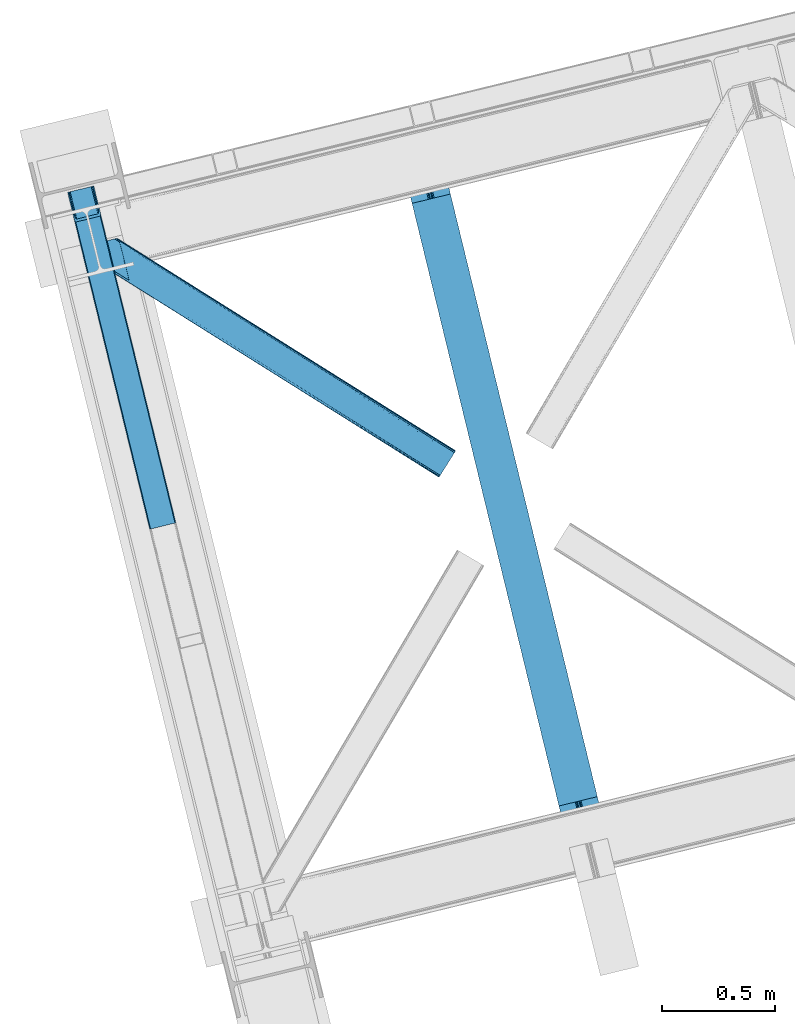
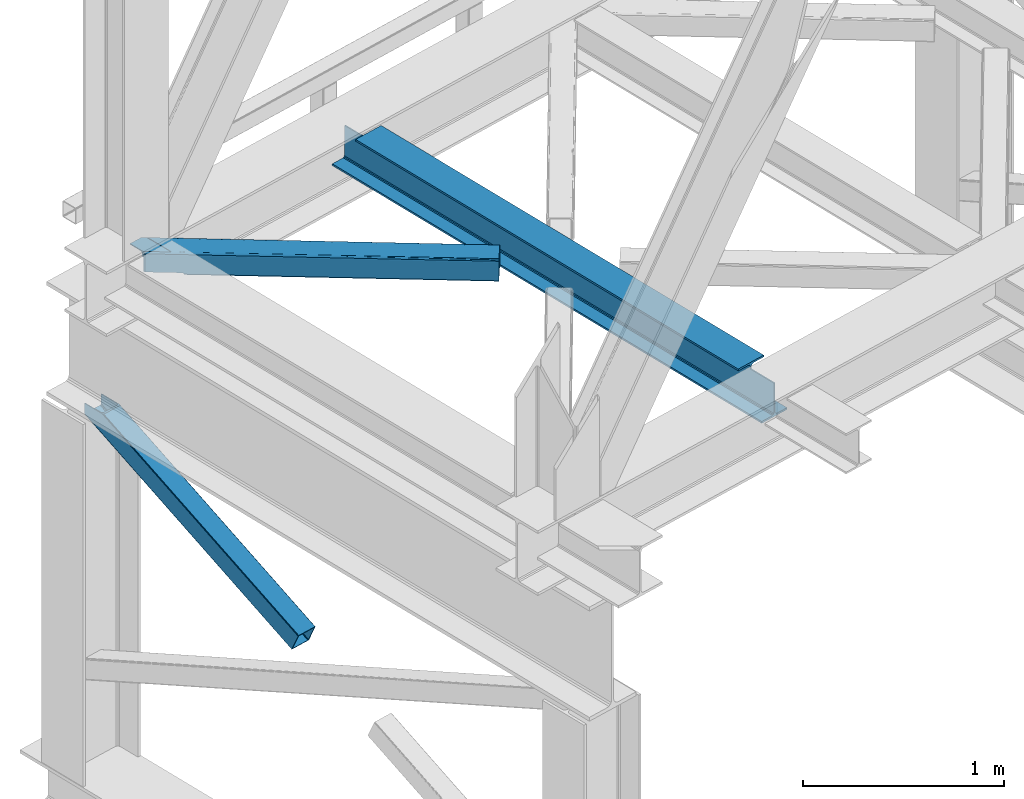
# One storey, part 24 of 93: 2 members, 1 beam.
"""IFC4 building model written with IfcOpenShell, lengths in millimetres."""

from ifc_helpers import new_model, entity, si_unit, converted_unit, derived_unit, direction, frame, origin, place, context, subcontext, project, spatial, triangles, polygons, material, type_object, element, save


model = new_model("IFC4")

# Units and contexts
model_context = context("Model", 3, precision=0.01, world=origin(), true_north=direction((6.12303176911189e-17, 1.0)))
plan_context = context("Plan", 3, precision=0.01, world=origin(), true_north=direction((6.12303176911189e-17, 1.0)))
body_context = subcontext(model_context, "Body", "Model", "MODEL_VIEW")
ifc_project = project(units=[si_unit("LENGTHUNIT", "METRE", prefix="MILLI"), si_unit("AREAUNIT", "SQUARE_METRE"), si_unit("VOLUMEUNIT", "CUBIC_METRE"), converted_unit("PLANEANGLEUNIT", "DEGREE", entity("IfcRatioMeasure", 0.0174532925199433), si_unit("PLANEANGLEUNIT", "RADIAN"), dimensions=[0, 0, 0, 0, 0, 0, 0]), si_unit("MASSUNIT", "GRAM", prefix="KILO"), derived_unit("MASSDENSITYUNIT", [(si_unit("MASSUNIT", "GRAM", prefix="KILO"), 1), (si_unit("LENGTHUNIT", "METRE"), -3)]), derived_unit("MOMENTOFINERTIAUNIT", [(si_unit("LENGTHUNIT", "METRE"), 4)]), si_unit("TIMEUNIT", "SECOND"), si_unit("FREQUENCYUNIT", "HERTZ"), si_unit("THERMODYNAMICTEMPERATUREUNIT", "DEGREE_CELSIUS"), derived_unit("THERMALTRANSMITTANCEUNIT", [(si_unit("MASSUNIT", "GRAM", prefix="KILO"), 1), (si_unit("THERMODYNAMICTEMPERATUREUNIT", "KELVIN"), -1), (si_unit("TIMEUNIT", "SECOND"), -3)]), derived_unit("VOLUMETRICFLOWRATEUNIT", [(si_unit("LENGTHUNIT", "METRE"), 3), (si_unit("TIMEUNIT", "SECOND"), -1)]), derived_unit("MASSFLOWRATEUNIT", [(si_unit("MASSUNIT", "GRAM", prefix="KILO"), 1), (si_unit("TIMEUNIT", "SECOND"), -1)]), derived_unit("ROTATIONALFREQUENCYUNIT", [(si_unit("TIMEUNIT", "SECOND"), -1)]), si_unit("ELECTRICCURRENTUNIT", "AMPERE"), si_unit("ELECTRICVOLTAGEUNIT", "VOLT"), si_unit("POWERUNIT", "WATT"), si_unit("FORCEUNIT", "NEWTON", prefix="KILO"), si_unit("ILLUMINANCEUNIT", "LUX"), si_unit("LUMINOUSFLUXUNIT", "LUMEN"), si_unit("LUMINOUSINTENSITYUNIT", "CANDELA"), derived_unit("USERDEFINED", [(si_unit("MASSUNIT", "GRAM", prefix="KILO"), -1), (si_unit("LENGTHUNIT", "METRE"), -2), (si_unit("TIMEUNIT", "SECOND"), 3), (si_unit("LUMINOUSFLUXUNIT", "LUMEN"), 1)]), derived_unit("LINEARVELOCITYUNIT", [(si_unit("LENGTHUNIT", "METRE"), 1), (si_unit("TIMEUNIT", "SECOND"), -1)]), si_unit("PRESSUREUNIT", "PASCAL"), derived_unit("USERDEFINED", [(si_unit("LENGTHUNIT", "METRE"), -2), (si_unit("MASSUNIT", "GRAM", prefix="KILO"), 1), (si_unit("TIMEUNIT", "SECOND"), -2)]), derived_unit("LINEARFORCEUNIT", [(si_unit("MASSUNIT", "GRAM", prefix="KILO"), 1), (si_unit("LENGTHUNIT", "METRE"), 1), (si_unit("TIMEUNIT", "SECOND"), -2), (si_unit("LENGTHUNIT", "METRE"), -1)]), derived_unit("PLANARFORCEUNIT", [(si_unit("MASSUNIT", "GRAM", prefix="KILO"), 1), (si_unit("LENGTHUNIT", "METRE"), 1), (si_unit("TIMEUNIT", "SECOND"), -2), (si_unit("LENGTHUNIT", "METRE"), -2)])], contexts=[model_context, plan_context])

# Site, building, storey
site_placement = place(None, origin())
site = spatial("IfcSite", under=ifc_project, at=site_placement, CompositionType="ELEMENT")
building_placement = place(site_placement, origin())
building = spatial("IfcBuilding", under=site, at=building_placement, CompositionType="ELEMENT")
storey_placement = place(building_placement, frame((0.0, 0.0, 15900.0)))
storey = spatial("IfcBuildingStorey", under=building, at=storey_placement, CompositionType="ELEMENT", Elevation=15900.0)

# Beam
ifc_material = material(Name="Metal painted (White)")
beam_type = type_object("IfcBeamType", PredefinedType="BEAM")
beam_placement = place(storey_placement, frame((-59635.8888397956, 3249.82596394136, 3441.0)))
element("IfcBeam", 1, at=beam_placement, inside=storey, type_object=beam_type, material=ifc_material, ObjectType="Steel Beam", PredefinedType="BEAM", context=body_context, shape_type="Tessellation", body=[
    polygons([(900.98534618944, 41.4445662733097, 11.000000000004), (900.98534618944, 41.4445662733097, 2.16573425859679e-12), (170.021610174761, 3040.13999372697, 2.16573425859679e-12), (170.021610174761, 3040.13999372697, 11.000000000004), (834.919806235823, 25.3403919499672, 11.000000000004), (103.956070221144, 3024.03581940363, 11.000000000004), (828.971056214531, 23.8903211957396, 12.2179274798217), (98.0073201998513, 3022.5857486494, 12.2179274798217), (823.927949458422, 22.66101056892, 15.6862915010192), (92.9642134437427, 3021.35643802258, 15.6862915010192), (820.558253255246, 21.8396114687124, 20.8770650821657), (89.5945172405668, 3020.53503892237, 20.8770650821657), (819.37497330556, 21.5511744621211, 27.0000000000047), (88.4112372908809, 3020.24660191578, 27.0000000000047), (81.6103728838801, 3018.58881926485, 27.0000000000047), (81.6103728838888, 3018.58881926485, 203.000000000006), (88.4112372908809, 3020.24660191578, 203.000000000006), (0.0, 2998.69542745366, 2.16573425859679e-12), (0.0, 2998.69542745366, 10.9999999999997), (66.0655399536345, 3014.799601777, 11.000000000004), (72.014289974927, 3016.24967253123, 12.2179274798217), (77.057396731027, 3017.47898315805, 15.6862915010192), (80.4270929341942, 3018.30038225826, 20.8770650821657), (819.374973305543, 21.5511744621206, 203.000000000006), (812.574108898559, 19.8933918111892, 203.000000000006), (812.574108898559, 19.8933918111892, 27.0000000000047), (811.390828948873, 19.6049548045968, 20.8770650821657), (808.021132745698, 18.7835557043893, 15.6862915010192), (802.978025989589, 17.5542450775691, 12.2179274798217), (797.029275968296, 16.1041743233431, 11.000000000004), (730.963736014679, 0.0, 10.9999999999997), (730.963736014679, 0.0, 2.16573425859679e-12), (779.675212882757, 184.415062601692, 203.069791966819), (128.020401343512, 2857.75452019162, 203.000000000006), (128.24328213265, 2856.8401777572, 203.617301946336), (128.256196377177, 2856.7871977843, 217.000003693143), (779.530009633824, 185.010597404072, 217.000003676718), (779.530880241731, 185.007025963192, 204.00000679514), (772.964911718311, 182.385463974443, 203.006342981529), (772.742064056782, 183.299815969774, 203.617301946336), (772.729149812263, 183.352795942669, 217.000003693143), (121.455336555608, 2855.1293963229, 217.000003676718), (121.45446594771, 2855.13296776378, 204.00000679514), (121.310166358664, 2855.72494066435, 203.076120467494), (121.219536936511, 2856.09673754069, 203.000000000006), (780.713494357868, 185.298194377515, 223.122939328039), (784.082490766547, 186.122464201394, 228.313710402595), (789.125126170554, 187.353708426698, 231.782072735464), (795.073705041275, 188.80448128138, 232.999999602236), (861.13915590679, 204.909021065315, 232.999999283132), (861.137682570352, 204.915065042188, 243.999994005812), (691.116301666431, 163.469558245298, 243.999994827032), (691.117775002877, 163.463514268425, 233.000000104353), (757.183225868401, 179.568054052359, 232.999999785253), (763.132130996731, 181.017488520583, 231.782072861012), (768.175695503862, 182.244921343719, 228.313710479427), (771.546082413602, 183.063487001148, 223.12293937232), (120.271851831572, 2854.84179934945, 223.122939328039), (116.902855422893, 2854.01752952557, 228.313710402595), (111.860220018869, 2852.78628530027, 231.782072735464), (105.911641148165, 2851.33551244559, 232.999999602236), (39.8461902826505, 2835.23097266165, 232.999999283128), (39.8476636190794, 2835.22492868478, 243.999994005812), (209.869044523001, 2876.67043548167, 243.999994827032), (209.867571186572, 2876.67647945854, 233.000000104357), (143.80212032104, 2860.57193967461, 232.999999785253), (137.85321519271, 2859.12250520639, 231.782072861012), (132.809650685579, 2857.89507238325, 228.313710479427), (129.439263775838, 2857.07650672582, 223.12293937232)], [[[1, 2, 3, 4]], [[5, 1, 4, 6]], [[7, 5, 6, 8]], [[9, 7, 8, 10]], [[11, 9, 10, 12]], [[13, 11, 12, 14]], [[15, 16, 17, 14, 12, 10, 8, 6, 4, 3, 18, 19, 20, 21, 22, 23]], [[13, 24, 25, 26, 27, 28, 29, 30, 31, 32, 2, 1, 5, 7, 9, 11]], [[2, 32, 18, 3]], [[32, 31, 19, 18]], [[31, 30, 20, 19]], [[27, 26, 15, 23]], [[28, 27, 23, 22]], [[29, 28, 22, 21]], [[30, 29, 21, 20]], [[33, 24, 13, 14, 17, 34, 35, 36, 37, 38]], [[25, 39, 40, 41, 42, 43, 44, 16, 15, 26]], [[39, 25, 24, 33]], [[45, 34, 17, 16]], [[41, 40, 38, 37, 46, 47, 48, 49, 50, 51, 52, 53, 54, 55, 56, 57]], [[42, 58, 59, 60, 61, 62, 63, 64, 65, 66, 67, 68, 69, 36, 35, 43]], [[46, 37, 36, 69]], [[47, 46, 69, 68]], [[48, 47, 68, 67]], [[49, 48, 67, 66]], [[50, 49, 66, 65]], [[51, 50, 65, 64]], [[52, 51, 64, 63]], [[53, 52, 63, 62]], [[54, 53, 62, 61]], [[55, 54, 61, 60]], [[56, 55, 60, 59]], [[57, 56, 59, 58]], [[41, 57, 58, 42]]], closed=False),
])

# Members
member_type_1 = type_object("IfcMemberType", PredefinedType="BRACE")
member_1_placement = place(storey_placement, frame((-61123.5760620117, 4641.45331878662, 1850.35374755859)))
element("IfcMember", 2, at=member_1_placement, inside=storey, type_object=member_type_1, ObjectType="Steel Vertical Brace", PredefinedType="BRACE", context=body_context, shape_type="Tessellation", body=[
    triangles([(109.78864746094, 1519.24680175781, 671.707836914062), (462.204345703125, 73.4905723571783, 0.0), (6.80423583984521, 1494.14368286133, 671.707836914062), (359.21993408203, 48.3871627807621, 0.0), (464.859997558597, 73.9117675781254, 0.48601684570167), (467.213342285155, 73.8434577941898, 1.86965332031104), (112.19315185547, 1519.83339385986, 672.832186889649), (468.910913085936, 73.2946540832527, 3.93929443359229), (114.59765625, 1520.41940460205, 673.956536865233), (469.687609863278, 72.3502349853516, 6.38100585937354), (115.592944335935, 1520.66183166504, 676.672650146484), (116.588232421876, 1520.90484008789, 679.387600708007), (353.104028320311, 43.9313301086431, 6.38100585937354), (0.0, 1492.48564453125, 679.387600708007), (0.99993896484375, 1492.7286529541, 676.672650146484), (353.359826660155, 45.128059387207, 3.93929443359229), (1.99522705077834, 1492.97108001709, 673.956536865233), (354.61091308594, 46.3954238891602, 1.86965332031104), (4.39973144531541, 1493.55709075928, 672.832186889649), (356.671252441403, 47.5395401000978, 0.48601684570167), (144.939990234372, 1404.59159088135, 741.646591186523), (116.588232421876, 1520.90484008789, 741.646591186523), (480.017211914063, 29.9807281494141, 102.993713378906), (28.3564086914048, 1376.17239532471, 741.646591186523), (0.0, 1492.48564453125, 741.646591186523), (363.428979492186, 1.5615325927738, 102.993713378906), (476.44998779297, 26.3725181579593, 108.888702392578), (144.465600585936, 1388.29607391357, 741.646591186523), (142.168066406251, 1386.40316619873, 741.646591186523), (473.896655273435, 25.5248954772951, 109.37471923828), (478.505676269531, 27.516634368897, 107.505065917969), (145.795751953126, 1392.41733398438, 741.646591186523), (479.761413574219, 28.7839988708502, 105.435424804688), (145.963183593747, 1398.13907775879, 741.646591186523), (39.1836547851563, 1361.29946594238, 741.646591186523), (370.912243652347, 0.421485900878906, 109.37471923828), (364.210327148438, 0.617113494873593, 105.435424804688), (30.4120971679658, 1369.97219238281, 741.646591186523), (365.90324707031, 0.0686004638673694, 107.505065917969), (33.1933227539048, 1364.96900939941, 741.646591186523), (368.256591796875, 0.0, 108.888702392578), (36.27685546875, 1361.92384643555, 741.646591186523), (138.061340332031, 1403.04052276611, 741.646591186523), (137.205578613284, 1415.21477966309, 741.646591186523), (111.728063964845, 1519.72061004639, 741.646591186523), (138.228771972659, 1408.76284790039, 741.646591186523), (136.731188964841, 1398.91926269531, 741.646591186523), (134.433654785156, 1397.02635498047, 741.646591186523), (35.1745971679702, 1377.96065826416, 741.646591186523), (32.3933715820313, 1382.96442260742, 741.646591186523), (30.333032226561, 1389.16346282959, 741.646591186523), (4.86016845703125, 1493.66987457275, 741.646591186523), (38.2534790039063, 1374.91491394043, 741.646591186523), (41.1649291992217, 1374.29111480713, 741.646591186523), (474.673352050784, 30.7952133178715, 98.4370147705085), (474.412902832031, 29.5981933593757, 100.87872619629), (473.161816406253, 28.3311195373535, 102.948367309571), (471.101477050783, 27.1867126464849, 104.330841064453), (468.552795410156, 26.3393806457525, 104.816857910155), (375.284069824222, 3.60414047241284, 104.816857910155), (372.62841796875, 3.18265457153393, 104.330841064453), (370.275073242185, 3.25154571533221, 102.948367309571), (368.577502441403, 3.79976806640661, 100.87872619629), (367.800805664061, 4.74418716430682, 98.4370147705085), (111.728063964845, 1519.72061004639, 684.873312377931), (465.315783691403, 69.1675804138185, 10.9377044677749), (4.86016845703125, 1493.66987457275, 684.873312377931), (358.447888183597, 43.1168449401857, 10.9377044677749), (462.84151611328, 70.660512542725, 6.42635192871239), (464.539086914061, 70.1122901916506, 8.49599304199364), (460.488171386722, 70.7294036865242, 5.04387817382667), (457.837170410159, 70.3079177856453, 4.557861328125), (359.954772949219, 45.5809387207037, 6.42635192871239), (362.015112304689, 46.7253456115723, 5.04387817382667), (358.70368652344, 44.3138648986824, 8.49599304199364), (364.563793945315, 47.5726776123047, 4.557861328125), (11.6597534179673, 1495.32733154297, 677.193548583986), (9.2552490234375, 1494.74132080078, 678.31789855957), (6.85074462890771, 1494.15531005859, 679.443411254884), (104.928479003909, 1518.06315307617, 677.193548583986), (107.332983398439, 1518.64916381836, 678.31789855957), (109.737487792969, 1519.23517456055, 679.443411254884), (5.85545654296584, 1493.91230163574, 682.158361816408), (110.732775878903, 1519.4781829834, 682.158361816408)], [[1, 2, 3], [4, 3, 2], [5, 2, 1], [6, 5, 7], [8, 6, 9], [10, 8, 11], [11, 12, 10], [9, 11, 8], [7, 9, 6], [1, 7, 5], [13, 14, 15], [16, 15, 17], [18, 17, 19], [20, 19, 3], [3, 4, 20], [19, 20, 18], [17, 18, 16], [15, 16, 13], [12, 21, 10], [21, 12, 22], [23, 10, 21], [24, 14, 13], [24, 25, 14], [13, 26, 24], [27, 28, 29], [29, 30, 27], [31, 32, 28], [28, 27, 31], [33, 34, 32], [32, 31, 33], [23, 21, 34], [34, 33, 23], [30, 29, 35], [35, 36, 30], [37, 38, 26], [24, 26, 38], [39, 40, 37], [38, 37, 40], [41, 42, 39], [40, 39, 42], [36, 35, 41], [42, 41, 35], [43, 34, 21], [22, 44, 21], [44, 22, 45], [44, 46, 21], [46, 43, 21], [47, 34, 43], [32, 29, 28], [32, 34, 47], [32, 48, 29], [29, 48, 35], [47, 48, 32], [24, 38, 49], [49, 50, 24], [50, 51, 24], [51, 25, 24], [52, 25, 51], [38, 53, 49], [54, 40, 35], [54, 35, 48], [54, 53, 40], [35, 40, 42], [53, 38, 40], [44, 55, 46], [56, 46, 55], [46, 56, 43], [57, 43, 56], [43, 57, 47], [58, 47, 57], [47, 58, 48], [59, 48, 58], [48, 59, 54], [60, 54, 59], [54, 60, 61], [61, 53, 54], [53, 61, 62], [62, 49, 53], [49, 62, 63], [63, 50, 49], [50, 63, 64], [64, 51, 50], [44, 65, 66], [44, 45, 65], [66, 55, 44], [67, 51, 68], [51, 67, 52], [64, 68, 51], [55, 23, 56], [57, 33, 31], [31, 27, 57], [23, 55, 10], [23, 33, 57], [57, 56, 23], [59, 30, 36], [30, 58, 57], [59, 58, 30], [30, 57, 27], [6, 69, 5], [66, 10, 55], [69, 8, 10], [70, 10, 66], [8, 69, 6], [69, 2, 5], [10, 70, 69], [69, 71, 2], [2, 72, 4], [72, 2, 71], [62, 26, 63], [36, 60, 59], [61, 36, 62], [36, 61, 60], [62, 36, 41], [64, 63, 26], [41, 39, 62], [37, 62, 39], [64, 26, 13], [37, 26, 62], [73, 20, 4], [74, 73, 4], [75, 13, 73], [76, 4, 72], [4, 76, 74], [18, 20, 73], [13, 68, 64], [16, 73, 13], [68, 13, 75], [73, 16, 18], [77, 1, 3], [3, 19, 78], [19, 17, 15], [19, 79, 78], [3, 78, 77], [79, 19, 15], [80, 1, 77], [9, 7, 11], [7, 1, 81], [81, 82, 7], [7, 82, 11], [80, 81, 1], [11, 82, 12], [83, 14, 67], [15, 14, 79], [83, 79, 14], [25, 67, 14], [25, 52, 67], [12, 84, 65], [84, 12, 82], [65, 22, 12], [22, 65, 45], [72, 80, 76], [77, 76, 80], [66, 65, 84], [70, 84, 82], [69, 82, 81], [71, 81, 80], [80, 72, 71], [81, 71, 69], [82, 69, 70], [84, 70, 66], [74, 76, 77], [73, 74, 78], [75, 73, 79], [68, 75, 83], [83, 67, 68], [79, 83, 75], [78, 79, 73], [77, 78, 74]]),
])
member_type_2 = type_object("IfcMemberType", PredefinedType="BRACE")
member_2_placement = place(storey_placement, frame((-60991.500402832, 4870.09285125732, 3511.0000579834)))
element("IfcMember", 3, at=member_2_placement, inside=storey, type_object=member_type_2, ObjectType="Steel Horizontal Brace", PredefinedType="BRACE", context=body_context, shape_type="Tessellation", body=[
    triangles([(207.717553710936, 841.06494140625, 0.0), (172.040661621089, 987.427519226074, 0.0), (1579.91751708985, 103.755294799805, 0.0), (1524.09766845703, 14.8223510742182, 0.0), (1589.22392578125, 118.577645874023, 17.5000946044929), (1588.51234130859, 117.449226379395, 10.8028289794929), (166.547973632813, 1009.96451568604, 10.8028289794929), (166.092187499999, 1011.82137908936, 17.5000946044929), (1586.49851074219, 114.236631774902, 5.12526855468968), (167.836267089842, 1004.67646636963, 5.12526855468968), (1583.48009033203, 109.42762298584, 1.33247680664135), (169.766381835936, 996.762414550781, 1.33247680664135), (1520.53974609375, 9.15002288818323, 1.33247680664135), (202.587634277341, 836.379180908203, 1.33247680664135), (208.508203124999, 837.822697448731, 0.155804443362285), (1517.52132568359, 4.34130477905273, 5.12526855468968), (194.895080566406, 834.504295349121, 5.12526855468968), (1515.50284423828, 1.12841949462836, 10.8028289794929), (189.755859375, 833.25146484375, 10.8028289794929), (1514.79591064453, 0.0, 17.5000946044929), (187.951318359374, 832.811375427246, 17.5000946044929), (204.378222656247, 836.815782165527, 12.1260040283232), (208.508203124999, 837.822697448731, 9.69243164062573), (199.648278808592, 835.663526916504, 17.9802978515654), (198.420446777345, 835.364126586914, 19.4999725341804), (187.951318359374, 832.811375427246, 19.4999725341804), (25.3054321289019, 934.895260620117, 19.4999725341804), (22.6823364257798, 945.669602966308, 19.4999725341804), (1514.79591064453, 0.0, 122.500662231447), (25.3054321289019, 934.895260620117, 122.500662231447), (1527.81837158203, 20.7510589599606, 6.99957275390625), (205.340954589839, 850.822485351562, 6.99957275390625), (207.559423828126, 841.724784851074, 8.88434143066479), (1524.26044921875, 15.0787307739256, 8.3320495605476), (1521.24202880859, 10.270303344726, 12.1260040283232), (1519.22354736328, 7.05712738037073, 17.8035644531265), (1518.51661376953, 5.92899856567328, 24.4996673583992), (22.9288330078125, 944.65280456543, 24.4996673583992), (174.417260742186, 977.669975280762, 6.99957275390625), (1576.19681396485, 97.8265869140623, 6.99957275390625), (168.966430664063, 1000.03372650147, 17.8803039550803), (170.212866210939, 994.918922424316, 12.1260040283232), (172.142980957033, 987.004870605469, 8.3320495605476), (168.831555175777, 1000.58543701172, 18.5000335693367), (166.092187499999, 1011.82137908936, 18.5000335693367), (1518.51661376953, 5.92899856567328, 115.501089477541), (22.9288330078125, 944.65280456543, 115.501089477541), (1527.81837158203, 20.7510589599606, 133.000021362306), (1524.26044921875, 15.0787307739256, 131.667544555665), (19.2592895507769, 959.711769104004, 131.667544555665), (16.9803588867144, 969.046664428711, 133.000021362306), (1521.24202880859, 10.270303344726, 127.87475280762), (21.1894042968706, 951.797717285156, 127.87475280762), (1519.22354736328, 7.05712738037073, 122.196029663086), (22.4776977539077, 946.509667968749, 122.196029663086), (168.515295410158, 1000.87960510254, 18.7407165527366), (165.808483886714, 1012.00160064697, 18.736065673831), (168.171130371091, 1001.19760894775, 19.0000030517585), (165.487573242186, 1012.20275115967, 19.0000030517585), (167.826965332031, 1001.51561279297, 19.2592895507842), (165.166662597658, 1012.4033203125, 19.2639404296897), (167.506054687496, 1001.80978088379, 19.4999725341804), (164.878308105464, 1012.58412322998, 19.4999725341804), (78.2928955078096, 1057.80520019531, 19.4999725341804), (88.7666748046831, 1060.35795135498, 19.4999725341804), (24.8542968749971, 936.752124023437, 129.197927856447), (23.5660034179673, 942.040173339844, 134.874325561526), (22.1195800781206, 947.964811706543, 137.999716186525), (0.0, 1038.72031860352, 137.999716186525), (0.0, 1038.72031860352, 133.000021362306), (1589.22392578125, 118.577645874023, 122.500662231447), (88.7666748046831, 1060.35795135498, 122.500662231447), (1584.79163818359, 111.520518493652, 17.8035644531265), (1585.50322265625, 112.648937988281, 24.4996673583992), (79.2788818359331, 1058.04588317871, 24.4996673583992), (1579.75938720703, 103.498915100097, 8.3320495605476), (1582.77780761719, 108.307342529297, 12.1260040283232), (64.6425659179658, 1054.47807769775, 131.667544555665), (55.5687011718765, 1052.26658477783, 133.000021362306), (76.0604736328096, 1057.26162872314, 137.999716186525), (81.8229125976577, 1058.66503143311, 134.874325561526), (72.3351196289077, 1056.3535446167, 127.87475280762), (77.474340820314, 1057.60637512207, 122.196029663086), (86.962133789064, 1059.91786193848, 129.197927856447), (79.2788818359331, 1058.04588317871, 115.501089477541), (1576.19681396485, 97.8265869140623, 133.000021362306), (1585.50322265625, 112.648937988281, 115.501089477541), (1584.79163818359, 111.520518493652, 122.196029663086), (1582.77780761719, 108.307342529297, 127.87475280762), (1579.75938720703, 103.498915100097, 131.667544555665), (1588.51234130859, 117.449226379395, 129.197927856447), (1586.49851074219, 114.236631774902, 134.874325561526), (1583.48009033203, 109.42762298584, 138.667117309571), (1579.91751708985, 103.755294799805, 139.999594116212), (1524.09766845703, 14.8223510742182, 139.999594116212), (1520.53974609375, 9.15002288818323, 138.667117309571), (1517.52132568359, 4.34130477905273, 134.874325561526), (1515.50284423828, 1.12841949462836, 129.197927856447), (98.1893554687485, 1043.37177886963, 137.999716186525), (139.386840820313, 874.360583496094, 137.999716186525), (137.842749023439, 884.922148132324, 139.999594116212), (139.824023437497, 876.794155883789, 138.999655151369), (140.051916503908, 875.630273437499, 138.667117309571), (139.805419921875, 874.273379516601, 138.076455688479), (139.917041015622, 874.907643127442, 138.353182983399), (98.7056030273452, 1042.87529754639, 138.076455688479), (99.5985717773438, 1040.78647155762, 138.634561157229), (99.1985961914033, 1041.72362365723, 138.383413696291), (100.184582519527, 1039.41271820068, 138.999655151369), (102.165856933592, 1031.28472595215, 139.999594116212), (140.033312988278, 875.544232177735, 138.629910278323)], [[1, 2, 3], [3, 4, 1], [5, 6, 7], [7, 8, 5], [6, 9, 10], [10, 7, 6], [9, 11, 12], [12, 10, 9], [11, 3, 2], [2, 12, 11], [13, 14, 15], [15, 4, 13], [15, 1, 4], [13, 16, 14], [17, 14, 16], [16, 18, 17], [19, 17, 18], [18, 20, 19], [21, 19, 20], [22, 23, 14], [22, 14, 17], [17, 19, 24], [23, 15, 14], [24, 22, 17], [19, 21, 25], [26, 25, 21], [19, 25, 24], [27, 28, 25], [25, 26, 27], [26, 29, 30], [20, 26, 21], [26, 20, 29], [26, 30, 27], [31, 32, 33], [34, 33, 23], [23, 35, 34], [23, 22, 35], [36, 35, 22], [37, 36, 24], [24, 25, 37], [37, 25, 38], [28, 38, 25], [22, 24, 36], [33, 34, 31], [39, 32, 40], [31, 40, 32], [41, 7, 10], [10, 42, 41], [12, 42, 10], [42, 12, 43], [7, 44, 8], [45, 8, 44], [7, 41, 44], [43, 12, 2], [33, 32, 1], [1, 39, 2], [39, 1, 32], [15, 33, 1], [39, 43, 2], [23, 33, 15], [46, 37, 38], [38, 47, 46], [48, 49, 50], [50, 51, 48], [49, 52, 53], [53, 50, 49], [52, 54, 55], [55, 53, 52], [54, 46, 47], [47, 55, 54], [45, 44, 56], [56, 57, 45], [57, 56, 58], [58, 59, 57], [59, 58, 60], [60, 61, 59], [61, 60, 62], [62, 63, 61], [64, 65, 63], [63, 62, 64], [47, 27, 30], [66, 55, 30], [55, 66, 67], [55, 47, 30], [38, 27, 47], [28, 27, 38], [53, 55, 67], [68, 51, 50], [51, 68, 69], [69, 70, 51], [50, 53, 68], [68, 53, 67], [5, 45, 71], [8, 45, 5], [45, 72, 71], [72, 45, 57], [72, 57, 59], [59, 61, 72], [63, 72, 61], [72, 63, 65], [73, 41, 42], [74, 75, 62], [62, 73, 74], [56, 73, 58], [56, 44, 73], [73, 60, 58], [73, 62, 60], [44, 41, 73], [75, 64, 62], [40, 76, 39], [43, 39, 76], [76, 77, 43], [42, 43, 77], [42, 77, 73], [78, 79, 80], [81, 82, 80], [78, 80, 82], [83, 81, 84], [79, 69, 80], [79, 70, 69], [83, 82, 81], [72, 85, 83], [85, 72, 65], [75, 65, 64], [65, 75, 85], [72, 83, 84], [51, 79, 86], [79, 51, 70], [86, 48, 51], [74, 87, 75], [85, 75, 87], [87, 88, 85], [83, 85, 88], [88, 89, 83], [82, 83, 89], [89, 90, 82], [78, 82, 90], [90, 86, 78], [79, 78, 86], [91, 89, 88], [87, 5, 71], [91, 88, 71], [91, 92, 89], [88, 87, 71], [89, 92, 93], [86, 94, 95], [94, 90, 93], [90, 94, 86], [90, 89, 93], [6, 77, 9], [74, 5, 87], [5, 73, 6], [73, 5, 74], [6, 73, 77], [3, 40, 4], [11, 9, 77], [77, 76, 11], [76, 40, 3], [3, 11, 76], [52, 96, 97], [95, 48, 86], [95, 49, 48], [49, 95, 96], [52, 49, 96], [46, 29, 20], [98, 54, 52], [97, 98, 52], [54, 98, 29], [46, 54, 29], [13, 35, 16], [4, 40, 31], [31, 34, 4], [34, 35, 13], [13, 4, 34], [18, 16, 35], [20, 37, 46], [36, 20, 18], [20, 36, 37], [36, 18, 35], [80, 68, 99], [80, 69, 68], [100, 99, 68], [95, 101, 102], [102, 96, 95], [102, 103, 96], [97, 104, 100], [100, 67, 97], [100, 68, 67], [96, 105, 104], [96, 103, 105], [104, 97, 96], [29, 98, 30], [66, 30, 98], [98, 97, 66], [67, 66, 97], [92, 81, 106], [106, 93, 92], [107, 93, 108], [106, 108, 93], [81, 80, 99], [107, 94, 93], [107, 109, 94], [109, 110, 94], [92, 91, 84], [84, 81, 92], [91, 71, 72], [72, 84, 91], [110, 101, 94], [95, 94, 101], [111, 102, 109], [109, 107, 111], [107, 108, 104], [108, 106, 104], [110, 109, 101], [102, 101, 109]]),
])

save(model, "model.ifc")
